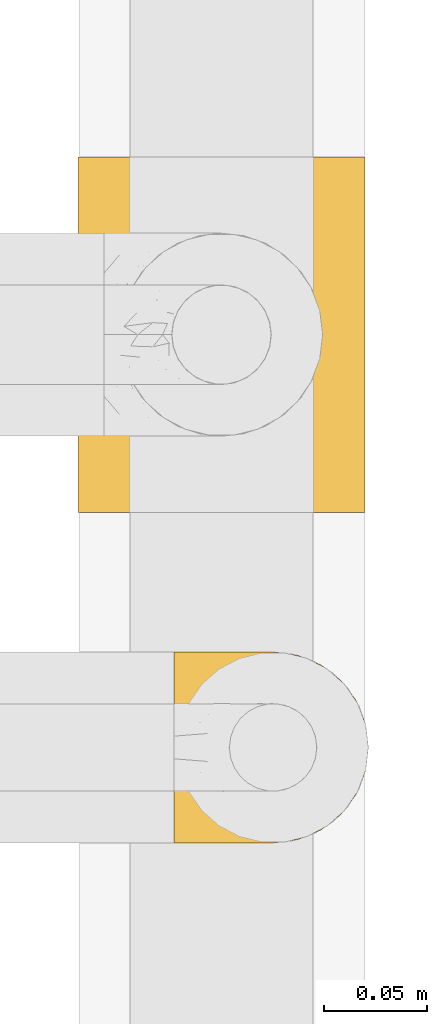
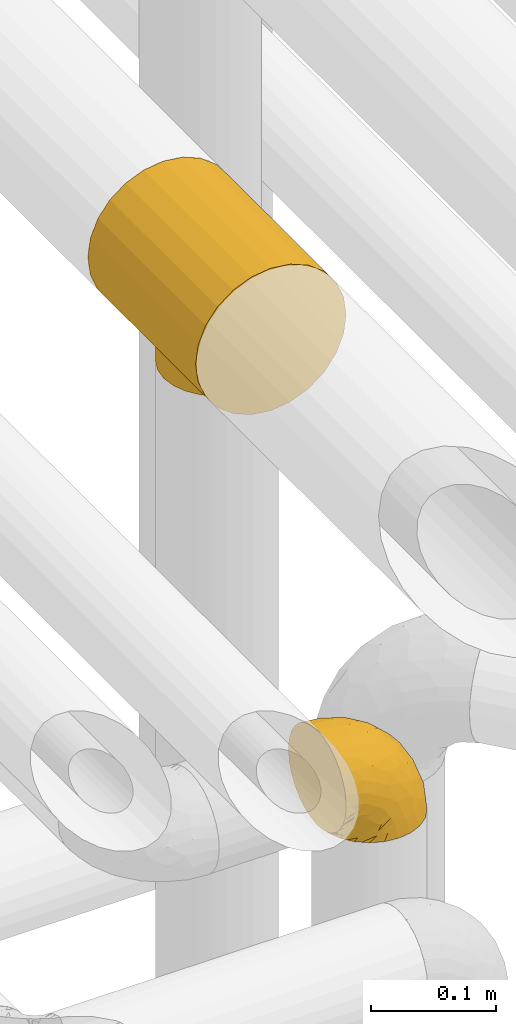
# One storey, part 209 of 827: 2 coverings.
"""IFC2X3 building model written with IfcOpenShell, lengths in millimetres."""

from ifc_helpers import new_model, entity, si_unit, converted_unit, derived_unit, direction, frame, origin, place, context, subcontext, project, spatial, faceted_brep, element, save


model = new_model("IFC2X3")

# Units and contexts
model_context = context("Model", 3, precision=0.01, world=origin(), true_north=direction((6.12303176911189e-17, 1.0)))
body_context = subcontext(model_context, "Body", "Model", "MODEL_VIEW")
ifc_project = project(units=[si_unit("LENGTHUNIT", "METRE", prefix="MILLI"), si_unit("AREAUNIT", "SQUARE_METRE"), si_unit("VOLUMEUNIT", "CUBIC_METRE"), converted_unit("PLANEANGLEUNIT", "DEGREE", entity("IfcRatioMeasure", 0.0174532925199433), si_unit("PLANEANGLEUNIT", "RADIAN"), dimensions=[0, 0, 0, 0, 0, 0, 0]), si_unit("MASSUNIT", "GRAM", prefix="KILO"), derived_unit("MASSDENSITYUNIT", [(si_unit("MASSUNIT", "GRAM", prefix="KILO"), 1), (si_unit("LENGTHUNIT", "METRE"), -3)]), derived_unit("MOMENTOFINERTIAUNIT", [(si_unit("LENGTHUNIT", "METRE"), 4)]), si_unit("TIMEUNIT", "SECOND"), si_unit("FREQUENCYUNIT", "HERTZ"), si_unit("THERMODYNAMICTEMPERATUREUNIT", "DEGREE_CELSIUS"), derived_unit("THERMALTRANSMITTANCEUNIT", [(si_unit("MASSUNIT", "GRAM", prefix="KILO"), 1), (si_unit("THERMODYNAMICTEMPERATUREUNIT", "KELVIN"), -1), (si_unit("TIMEUNIT", "SECOND"), -3)]), derived_unit("VOLUMETRICFLOWRATEUNIT", [(si_unit("LENGTHUNIT", "METRE"), 3), (si_unit("TIMEUNIT", "SECOND"), -1)]), derived_unit("MASSFLOWRATEUNIT", [(si_unit("MASSUNIT", "GRAM", prefix="KILO"), 1), (si_unit("TIMEUNIT", "SECOND"), -1)]), derived_unit("ROTATIONALFREQUENCYUNIT", [(si_unit("TIMEUNIT", "SECOND"), -1)]), si_unit("ELECTRICCURRENTUNIT", "AMPERE"), si_unit("ELECTRICVOLTAGEUNIT", "VOLT"), si_unit("POWERUNIT", "WATT"), si_unit("FORCEUNIT", "NEWTON", prefix="KILO"), si_unit("ILLUMINANCEUNIT", "LUX"), si_unit("LUMINOUSFLUXUNIT", "LUMEN"), si_unit("LUMINOUSINTENSITYUNIT", "CANDELA"), derived_unit("USERDEFINED", [(si_unit("MASSUNIT", "GRAM", prefix="KILO"), -1), (si_unit("LENGTHUNIT", "METRE"), -2), (si_unit("TIMEUNIT", "SECOND"), 3), (si_unit("LUMINOUSFLUXUNIT", "LUMEN"), 1)]), derived_unit("LINEARVELOCITYUNIT", [(si_unit("LENGTHUNIT", "METRE"), 1), (si_unit("TIMEUNIT", "SECOND"), -1)]), si_unit("PRESSUREUNIT", "PASCAL"), derived_unit("USERDEFINED", [(si_unit("LENGTHUNIT", "METRE"), -2), (si_unit("MASSUNIT", "GRAM", prefix="KILO"), 1), (si_unit("TIMEUNIT", "SECOND"), -2)]), derived_unit("LINEARFORCEUNIT", [(si_unit("MASSUNIT", "GRAM", prefix="KILO"), 1), (si_unit("LENGTHUNIT", "METRE"), 1), (si_unit("TIMEUNIT", "SECOND"), -2), (si_unit("LENGTHUNIT", "METRE"), -1)]), derived_unit("PLANARFORCEUNIT", [(si_unit("MASSUNIT", "GRAM", prefix="KILO"), 1), (si_unit("LENGTHUNIT", "METRE"), 1), (si_unit("TIMEUNIT", "SECOND"), -2), (si_unit("LENGTHUNIT", "METRE"), -2)])], contexts=[model_context])

# Site, building, storey
site_placement = place(None, origin())
site = spatial("IfcSite", under=ifc_project, at=site_placement, CompositionType="ELEMENT")
building_placement = place(site_placement, origin())
building = spatial("IfcBuilding", under=site, at=building_placement, CompositionType="ELEMENT")
storey_placement = place(building_placement, frame((0.0, 0.0, 28200.0)))
storey = spatial("IfcBuildingStorey", under=building, at=storey_placement, Name="08", CompositionType="ELEMENT", Elevation=28200.0)

# Coverings
covering_1_placement = place(storey_placement, frame((35893.45, 11758.41, 3150.4)))
element("IfcCovering", 1, at=covering_1_placement, inside=storey, Name=":ADSK_", ObjectType=":ADSK_", PredefinedType="INSULATION", context=body_context, shape_type="Brep", body=[
    faceted_brep([(1.6, 11.68, 78.41), (1.6, 19.0, 85.72), (1.6, 27.76, 91.22), (1.6, 37.52, 94.64), (1.6, 47.8, 95.8), (1.6, 58.08, 94.64), (1.6, 67.85, 91.22), (1.6, 76.61, 85.71), (1.6, 83.92, 78.39), (1.6, 89.42, 69.63), (1.6, 92.84, 59.87), (1.6, 94.0, 49.6), (1.6, 93.53, 45.45), (1.6, 93.18, 42.38), (1.6, 92.84, 39.31), (1.6, 91.13, 34.43), (1.6, 89.42, 29.54), (1.6, 86.66, 25.16), (1.6, 83.91, 20.78), (1.6, 80.25, 17.13), (1.6, 76.59, 13.47), (1.6, 67.83, 7.97), (1.6, 62.95, 6.26), (1.6, 58.07, 4.55), (1.6, 47.8, 3.4), (1.6, 37.51, 4.55), (1.6, 32.63, 6.26), (1.6, 27.74, 7.97), (1.6, 18.98, 13.48), (1.6, 15.33, 17.14), (1.6, 11.67, 20.8), (1.6, 8.92, 25.18), (1.6, 6.17, 29.56), (1.6, 4.46, 34.44), (1.6, 2.75, 39.32), (1.6, 2.41, 42.39), (1.6, 2.06, 45.45), (1.6, 1.6, 49.6), (1.6, 2.75, 59.88), (1.6, 6.17, 69.65), (3.4, 47.8, 1.6), (4.97, 59.75, 1.6), (9.58, 70.9, 1.6), (13.26, 75.68, 1.6), (16.93, 80.46, 1.6), (21.71, 84.13, 1.6), (26.5, 87.81, 1.6), (32.07, 90.11, 1.6), (37.64, 92.42, 1.6), (41.25, 92.9, 1.6), (43.34, 93.17, 1.6), (45.42, 93.45, 1.6), (49.6, 94.0, 1.6), (61.55, 92.42, 1.6), (72.7, 87.81, 1.6), (82.26, 80.46, 1.6), (89.61, 70.9, 1.6), (94.22, 59.75, 1.6), (95.8, 47.8, 1.6), (94.22, 35.84, 1.6), (89.61, 24.7, 1.6), (82.26, 15.13, 1.6), (72.7, 7.78, 1.6), (61.55, 3.17, 1.6), (49.6, 1.6, 1.6), (45.42, 2.14, 1.6), (41.25, 2.69, 1.6), (37.64, 3.17, 1.6), (32.07, 5.48, 1.6), (26.5, 7.78, 1.6), (21.71, 11.46, 1.6), (16.93, 15.13, 1.6), (13.26, 19.91, 1.6), (9.58, 24.7, 1.6), (4.97, 35.84, 1.6), (81.55, 23.61, 36.81), (90.4, 31.99, 23.28), (83.0, 35.87, 45.8), (91.18, 47.8, 30.7), (93.13, 40.43, 21.2), (94.0, 47.8, 12.96), (66.19, 31.83, 66.19), (70.92, 23.37, 54.51), (85.95, 21.41, 17.98), (49.74, 3.07, 36.69), (35.54, 1.6, 35.54), (38.14, 1.6, 31.64), (40.74, 1.6, 27.75), (43.34, 1.6, 23.86), (45.94, 1.6, 19.96), (77.59, 13.45, 22.8), (71.17, 15.25, 42.67), (65.81, 8.07, 33.21), (59.03, 16.0, 59.45), (45.85, 17.34, 71.5), (45.79, 10.58, 62.66), (41.42, 5.34, 54.5), (34.51, 2.39, 47.57), (56.04, 8.36, 48.81), (15.15, 10.04, 74.98), (56.51, 2.59, 18.7), (68.39, 6.28, 15.75), (23.33, 34.28, 91.17), (42.86, 38.73, 85.28), (39.42, 27.25, 82.58), (53.58, 29.88, 75.78), (59.17, 38.6, 74.98), (59.06, 23.44, 67.27), (22.63, 25.25, 87.38), (20.55, 17.23, 82.04), (12.96, 47.8, 94.0), (56.96, 47.8, 77.8), (67.38, 47.8, 67.38), (18.72, 2.53, 56.2), (5.33, 1.6, 48.85), (9.07, 1.6, 48.11), (11.79, 1.6, 47.57), (14.51, 1.6, 47.03), (17.24, 1.6, 46.48), (19.96, 1.6, 45.94), (21.03, 5.71, 65.78), (46.48, 1.6, 17.24), (47.03, 1.6, 14.51), (47.57, 1.6, 11.79), (48.11, 1.6, 9.07), (48.48, 1.6, 7.2), (48.85, 1.6, 5.33), (30.7, 47.8, 91.18), (23.86, 1.6, 43.34), (27.75, 1.6, 40.74), (31.64, 1.6, 38.14), (31.26, 11.89, 72.73), (77.8, 47.8, 56.96), (72.75, 39.69, 62.23), (43.83, 47.8, 84.49), (84.49, 47.8, 43.83), (14.58, 13.84, 12.05), (16.17, 9.16, 18.95), (10.82, 15.79, 13.02), (4.64, 25.75, 8.34), (7.71, 16.09, 14.63), (25.13, 7.51, 11.09), (32.66, 3.99, 13.66), (34.94, 2.66, 20.08), (36.76, 3.16, 9.61), (40.48, 2.35, 9.48), (39.25, 2.23, 16.1), (3.69, 38.35, 3.42), (13.99, 6.18, 26.63), (21.85, 2.7, 33.72), (17.93, 2.93, 34.77), (15.11, 16.01, 6.75), (21.14, 9.08, 13.31), (12.7, 9.3, 21.11), (7.21, 11.68, 19.94), (10.45, 21.65, 6.04), (32.27, 4.65, 8.67), (25.68, 3.65, 26.11), (22.18, 3.61, 29.3), (18.79, 12.8, 6.32), (10.12, 2.43, 39.92), (9.47, 6.83, 27.05), (11.29, 3.7, 34.4), (2.87, 47.8, 2.87), (31.16, 3.37, 20.92), (6.31, 7.03, 27.43), (25.62, 7.87, 7.54), (21.18, 7.26, 18.45), (28.81, 3.41, 23.88), (7.45, 23.81, 7.77), (21.17, 88.32, 18.43), (16.17, 86.42, 18.93), (25.69, 91.93, 26.08), (48.11, 94.0, 9.07), (48.85, 94.0, 5.33), (47.03, 94.0, 14.51), (47.57, 94.0, 11.79), (3.69, 57.24, 3.42), (7.44, 71.76, 7.76), (14.51, 94.0, 47.03), (11.79, 94.0, 47.57), (5.33, 94.0, 48.85), (9.07, 94.0, 48.11), (7.71, 79.49, 14.62), (9.47, 88.75, 27.03), (34.94, 92.93, 20.08), (31.16, 92.22, 20.92), (40.74, 94.0, 27.75), (38.14, 94.0, 31.64), (18.79, 82.79, 6.33), (36.76, 92.43, 9.61), (40.48, 93.24, 9.48), (4.63, 69.82, 8.33), (21.14, 86.5, 13.3), (15.11, 79.57, 6.74), (14.58, 81.74, 12.04), (43.34, 94.0, 23.86), (45.94, 94.0, 19.96), (39.25, 93.36, 16.1), (7.21, 83.9, 19.93), (12.69, 86.28, 21.1), (10.14, 93.16, 39.92), (21.81, 92.88, 33.68), (22.19, 91.98, 29.28), (14.0, 89.41, 26.62), (6.66, 88.82, 27.87), (17.92, 92.66, 34.75), (10.45, 73.93, 6.04), (31.64, 94.0, 38.14), (10.64, 79.5, 12.79), (11.31, 91.89, 34.41), (19.96, 94.0, 45.94), (23.86, 94.0, 43.34), (27.75, 94.0, 40.74), (32.66, 91.6, 13.66), (46.48, 94.0, 17.24), (32.27, 90.94, 8.67), (25.13, 88.08, 11.09), (35.54, 94.0, 35.54), (28.77, 92.16, 23.83), (23.36, 86.13, 6.03), (17.24, 94.0, 46.48), (47.58, 93.2, 34.52), (93.13, 55.16, 21.2), (77.44, 82.02, 23.82), (66.78, 84.29, 41.32), (71.68, 76.94, 47.62), (74.96, 68.33, 52.66), (81.55, 71.98, 36.81), (36.7, 92.52, 49.75), (56.9, 92.9, 19.07), (83.0, 59.72, 45.8), (90.4, 63.6, 23.28), (67.83, 88.89, 21.35), (85.95, 74.18, 17.98), (39.41, 68.35, 82.57), (23.33, 61.33, 91.17), (42.87, 56.86, 85.27), (53.92, 68.62, 73.89), (66.19, 63.76, 66.19), (64.12, 72.19, 62.43), (33.13, 88.69, 63.53), (23.1, 92.19, 58.45), (16.98, 89.75, 67.16), (72.75, 55.9, 62.22), (23.77, 77.99, 81.54), (18.41, 85.21, 74.8), (43.7, 74.99, 75.83), (54.53, 90.23, 41.45), (55.72, 59.86, 76.72), (17.73, 70.75, 88.2), (38.98, 81.72, 71.6), (50.28, 86.53, 56.23), (59.02, 79.6, 59.44)], [[[0, 1, 2, 3, 4, 5, 6, 7, 8, 9, 10, 11, 12, 13, 14, 15, 16, 17, 18, 19, 20, 21, 22, 23, 24, 25, 26, 27, 28, 29, 30, 31, 32, 33, 34, 35, 36, 37, 38, 39]], [[40, 41, 42, 43, 44, 45, 46, 47, 48, 49, 50, 51, 52, 53, 54, 55, 56, 57, 58, 59, 60, 61, 62, 63, 64, 65, 66, 67, 68, 69, 70, 71, 72, 73, 74]], [[75, 76, 77]], [[78, 79, 80]], [[77, 81, 82]], [[76, 75, 83]], [[84, 85, 86, 87, 88, 89]], [[90, 91, 92]], [[76, 60, 59]], [[93, 94, 95]], [[90, 62, 61]], [[83, 61, 60]], [[96, 97, 84]], [[98, 93, 95]], [[0, 39, 99]], [[100, 84, 89]], [[62, 101, 63]], [[2, 102, 3]], [[92, 84, 100]], [[103, 102, 104]], [[103, 105, 106]], [[93, 107, 94]], [[1, 108, 2]], [[92, 101, 90]], [[108, 1, 109]], [[102, 110, 3]], [[93, 82, 107]], [[102, 108, 104]], [[111, 106, 112]], [[109, 0, 99]], [[113, 37, 114, 115, 116, 117, 118, 119]], [[120, 38, 113]], [[100, 89, 121, 122, 123, 124, 125, 126, 64]], [[127, 102, 103]], [[97, 119, 128, 129, 130, 85]], [[99, 120, 131]], [[132, 133, 77]], [[59, 80, 79]], [[1, 0, 109]], [[98, 84, 92]], [[94, 109, 131]], [[120, 39, 38]], [[93, 91, 82]], [[104, 94, 105]], [[97, 113, 119]], [[95, 120, 96]], [[83, 90, 61]], [[91, 93, 98]], [[64, 63, 100]], [[100, 63, 101]], [[77, 76, 79]], [[133, 106, 81]], [[84, 97, 85]], [[113, 96, 120]], [[113, 97, 96]], [[37, 113, 38]], [[110, 102, 127]], [[110, 4, 3]], [[103, 111, 134, 127]], [[90, 75, 91]], [[82, 81, 107]], [[91, 75, 82]], [[77, 82, 75]], [[76, 83, 60]], [[90, 83, 75]], [[105, 107, 81]], [[94, 131, 95]], [[105, 94, 107]], [[109, 94, 104]], [[120, 95, 131]], [[98, 95, 96]], [[84, 98, 96]], [[98, 92, 91]], [[106, 105, 81]], [[103, 104, 105]], [[112, 106, 133]], [[103, 106, 111]], [[112, 133, 132]], [[81, 77, 133]], [[77, 78, 135, 132]], [[120, 99, 39]], [[109, 99, 131]], [[59, 58, 80]], [[59, 79, 76]], [[90, 101, 62]], [[100, 101, 92]], [[2, 108, 102]], [[109, 104, 108]], [[78, 77, 79]], [[136, 137, 138]], [[27, 139, 140]], [[141, 142, 143]], [[144, 145, 121]], [[146, 89, 88]], [[147, 139, 25]], [[148, 149, 150]], [[136, 151, 152]], [[147, 40, 74]], [[24, 147, 25]], [[140, 153, 154]], [[33, 116, 34]], [[73, 151, 155]], [[114, 37, 36, 35, 34, 116, 115]], [[146, 156, 144]], [[157, 85, 130]], [[158, 149, 148]], [[151, 159, 152]], [[117, 33, 160]], [[29, 154, 161]], [[155, 74, 73]], [[162, 128, 119]], [[66, 65, 64, 126, 125, 124, 123, 122, 67]], [[163, 147, 24]], [[27, 140, 28]], [[149, 129, 150]], [[139, 27, 26, 25]], [[68, 144, 69]], [[129, 128, 150]], [[164, 87, 86]], [[130, 129, 149]], [[122, 145, 67]], [[154, 153, 148]], [[162, 119, 160]], [[165, 30, 161]], [[150, 161, 148]], [[128, 162, 150]], [[30, 165, 31]], [[145, 144, 68]], [[89, 146, 144]], [[87, 164, 143]], [[166, 156, 142]], [[88, 87, 143]], [[162, 161, 150]], [[161, 30, 29]], [[154, 29, 28]], [[140, 154, 28]], [[161, 154, 148]], [[140, 137, 153]], [[158, 148, 153]], [[157, 130, 158]], [[153, 137, 158]], [[158, 137, 157]], [[167, 137, 136]], [[168, 85, 157]], [[152, 168, 167]], [[167, 168, 157]], [[164, 152, 141]], [[151, 73, 72]], [[159, 72, 71]], [[88, 142, 146]], [[144, 156, 69]], [[146, 142, 156]], [[70, 166, 71]], [[142, 141, 166]], [[70, 69, 156]], [[141, 159, 71]], [[167, 136, 152]], [[138, 137, 140]], [[155, 136, 169]], [[136, 155, 151]], [[74, 155, 169]], [[152, 159, 141]], [[151, 72, 159]], [[168, 152, 164]], [[137, 167, 157]], [[164, 86, 168]], [[85, 168, 86]], [[116, 33, 117]], [[130, 149, 158]], [[67, 145, 68]], [[121, 89, 144]], [[145, 122, 121]], [[40, 147, 163]], [[169, 147, 74]], [[160, 33, 32]], [[162, 160, 32]], [[160, 119, 118, 117]], [[139, 147, 169]], [[139, 169, 138]], [[162, 32, 31]], [[141, 143, 164]], [[88, 143, 142]], [[71, 166, 141]], [[156, 166, 70]], [[139, 138, 140]], [[169, 136, 138]], [[161, 162, 165]], [[162, 31, 165]], [[170, 171, 172]], [[173, 174, 52, 51, 50, 49, 48, 175, 176]], [[177, 178, 41]], [[179, 15, 180]], [[12, 11, 181, 182, 180, 14, 13]], [[183, 21, 20]], [[19, 18, 184]], [[185, 186, 187]], [[186, 188, 187]], [[43, 189, 44]], [[190, 191, 47]], [[23, 22, 21, 192]], [[193, 194, 195]], [[40, 163, 177]], [[196, 197, 198]], [[24, 23, 177]], [[199, 200, 183]], [[201, 15, 179]], [[47, 46, 190]], [[202, 203, 204]], [[203, 172, 171]], [[205, 206, 184]], [[207, 41, 178]], [[16, 15, 201]], [[14, 180, 15]], [[204, 203, 200]], [[208, 203, 202]], [[163, 24, 177]], [[48, 47, 191]], [[198, 197, 190]], [[199, 184, 204]], [[171, 195, 209]], [[210, 211, 212]], [[206, 212, 213]], [[205, 17, 210]], [[184, 206, 204]], [[210, 212, 206]], [[185, 196, 214]], [[190, 215, 191]], [[216, 45, 214]], [[186, 217, 193]], [[190, 216, 198]], [[199, 20, 19]], [[196, 185, 187]], [[199, 183, 20]], [[184, 199, 19]], [[199, 204, 200]], [[206, 202, 204]], [[171, 183, 200]], [[203, 208, 172]], [[172, 208, 218]], [[171, 200, 203]], [[218, 188, 219]], [[195, 170, 193]], [[217, 186, 185]], [[193, 219, 186]], [[193, 170, 219]], [[207, 194, 42]], [[217, 220, 189]], [[216, 190, 46]], [[214, 196, 198]], [[44, 220, 45]], [[214, 198, 216]], [[216, 46, 45]], [[214, 45, 220]], [[42, 194, 43]], [[189, 193, 217]], [[207, 195, 194]], [[209, 195, 178]], [[41, 207, 42]], [[195, 207, 178]], [[43, 194, 189]], [[193, 189, 194]], [[171, 170, 195]], [[170, 172, 219]], [[218, 219, 172]], [[188, 186, 219]], [[206, 213, 202]], [[208, 202, 213]], [[201, 210, 16]], [[215, 190, 197]], [[215, 175, 191]], [[175, 48, 191]], [[201, 179, 221, 211]], [[210, 201, 211]], [[23, 192, 177]], [[40, 177, 41]], [[183, 209, 192]], [[183, 192, 21]], [[192, 178, 177]], [[205, 18, 17]], [[17, 16, 210]], [[217, 185, 214]], [[189, 220, 44]], [[214, 220, 217]], [[192, 209, 178]], [[171, 209, 183]], [[206, 205, 210]], [[18, 205, 184]], [[222, 197, 196, 187, 188, 218]], [[57, 223, 80]], [[224, 225, 226]], [[226, 227, 228]], [[229, 218, 208, 213, 212, 211]], [[230, 52, 174, 173, 176, 175, 215, 197]], [[231, 232, 228]], [[231, 78, 223]], [[223, 57, 232]], [[224, 233, 225]], [[233, 54, 53]], [[234, 232, 56]], [[56, 55, 234]], [[234, 224, 228]], [[235, 236, 237]], [[224, 55, 54]], [[238, 239, 240]], [[52, 230, 53]], [[241, 242, 243]], [[231, 227, 244]], [[11, 10, 242]], [[236, 6, 5]], [[7, 245, 8]], [[8, 246, 9]], [[238, 247, 235]], [[222, 229, 248]], [[242, 211, 221, 179, 180, 182, 181, 11]], [[233, 53, 230]], [[111, 112, 249]], [[250, 6, 236]], [[246, 251, 241]], [[6, 250, 7]], [[127, 236, 110]], [[248, 229, 252]], [[246, 8, 245]], [[235, 245, 250]], [[236, 5, 110]], [[235, 249, 238]], [[237, 236, 127]], [[243, 9, 246]], [[252, 229, 241]], [[56, 232, 57]], [[222, 230, 197]], [[225, 248, 252]], [[248, 233, 230]], [[54, 233, 224]], [[231, 228, 227]], [[244, 132, 231]], [[248, 225, 233]], [[226, 225, 253]], [[235, 250, 236]], [[245, 7, 250]], [[251, 246, 245]], [[243, 246, 241]], [[247, 245, 235]], [[252, 251, 253]], [[229, 222, 218]], [[230, 222, 248]], [[5, 4, 110]], [[237, 127, 134, 111]], [[238, 249, 239]], [[224, 234, 55]], [[232, 234, 228]], [[242, 241, 229]], [[10, 9, 243]], [[211, 242, 229]], [[10, 243, 242]], [[80, 223, 78]], [[80, 58, 57]], [[231, 223, 232]], [[227, 240, 239]], [[224, 226, 228]], [[240, 226, 253]], [[227, 239, 244]], [[226, 240, 227]], [[251, 247, 253]], [[240, 253, 247]], [[249, 235, 237]], [[237, 111, 249]], [[244, 239, 249]], [[112, 244, 249]], [[135, 78, 231, 132]], [[112, 132, 244]], [[247, 238, 240]], [[245, 247, 251]], [[251, 252, 241]], [[225, 252, 253]]]),
])
covering_2_placement = place(storey_placement, frame((35847.02, 11920.08, 3477.0)))
element("IfcCovering", 2, at=covering_2_placement, inside=storey, Name=":ADSK_", ObjectType=":ADSK_", PredefinedType="INSULATION", context=body_context, shape_type="Brep", body=[
    faceted_brep([(3.96, 172.0, 90.97), (10.9, 172.0, 107.72), (21.94, 172.0, 122.11), (36.32, 172.0, 133.15), (53.07, 172.0, 140.08), (71.05, 172.0, 142.45), (89.02, 172.0, 140.08), (105.77, 172.0, 133.15), (120.15, 172.0, 122.11), (131.19, 172.0, 107.72), (138.13, 172.0, 90.97), (140.5, 172.0, 73.0), (138.13, 172.0, 55.03), (131.19, 172.0, 38.27), (120.15, 172.0, 23.89), (105.77, 172.0, 12.85), (97.4, 172.0, 9.39), (89.02, 172.0, 5.92), (80.03, 172.0, 4.73), (71.05, 172.0, 3.55), (62.06, 172.0, 4.73), (53.07, 172.0, 5.92), (44.7, 172.0, 9.39), (36.32, 172.0, 12.85), (21.94, 172.0, 23.89), (10.9, 172.0, 38.27), (3.96, 172.0, 55.03), (1.6, 172.0, 73.0), (120.15, 0.0, 122.11), (105.77, 0.0, 133.15), (89.02, 0.0, 140.08), (71.05, 0.0, 142.45), (53.07, 0.0, 140.08), (36.32, 0.0, 133.15), (21.94, 0.0, 122.11), (10.9, 0.0, 107.73), (3.96, 0.0, 90.97), (1.6, 0.0, 73.0), (3.96, 0.0, 55.03), (10.9, 0.0, 38.28), (21.94, 0.0, 23.89), (36.32, 0.0, 12.85), (44.7, 0.0, 9.39), (53.07, 0.0, 5.92), (62.06, 0.0, 4.73), (71.05, 0.0, 3.55), (80.03, 0.0, 4.73), (89.02, 0.0, 5.92), (97.4, 0.0, 9.39), (105.77, 0.0, 12.85), (120.15, 0.0, 23.89), (131.19, 0.0, 38.28), (138.13, 0.0, 55.03), (140.5, 0.0, 73.0), (138.13, 0.0, 90.97), (131.19, 0.0, 107.73), (109.48, 55.36, 15.15), (115.18, 64.37, 19.38), (92.88, 130.03, 7.07), (118.88, 74.72, 22.65), (82.39, 38.18, 4.48), (120.2, 86.0, 23.93), (118.88, 97.28, 22.65), (82.39, 133.82, 4.48), (76.72, 134.49, 4.02), (71.05, 135.15, 3.55), (109.48, 116.64, 15.15), (115.18, 107.63, 19.38), (102.0, 47.82, 10.83), (92.88, 41.97, 7.07), (71.05, 36.85, 3.55), (76.72, 37.51, 4.02), (87.64, 40.07, 5.78), (102.0, 124.18, 10.83), (87.64, 131.93, 5.78), (59.7, 38.18, 4.48), (40.09, 47.82, 10.83), (49.21, 41.97, 7.07), (54.46, 40.07, 5.78), (65.38, 134.49, 4.02), (59.7, 133.82, 4.48), (40.09, 124.18, 10.83), (49.21, 130.03, 7.07), (32.61, 116.64, 15.15), (54.46, 131.93, 5.78), (32.61, 55.36, 15.15), (26.91, 64.37, 19.38), (23.21, 74.72, 22.65), (65.38, 37.51, 4.02), (21.9, 86.0, 23.93), (26.91, 107.63, 19.38), (23.21, 97.28, 22.65), (118.52, 73.28, 0.0), (113.61, 61.42, 0.0), (105.8, 51.25, 0.0), (95.62, 43.43, 0.0), (89.69, 40.98, 0.0), (83.77, 38.52, 0.0), (77.41, 37.69, 0.0), (71.05, 36.85, 0.0), (64.68, 37.69, 0.0), (58.32, 38.52, 0.0), (52.4, 40.98, 0.0), (46.47, 43.43, 0.0), (36.29, 51.25, 0.0), (28.48, 61.42, 0.0), (23.57, 73.28, 0.0), (21.9, 86.0, 0.0), (23.57, 98.72, 0.0), (28.48, 110.57, 0.0), (36.29, 120.75, 0.0), (46.47, 128.57, 0.0), (52.4, 131.02, 0.0), (58.32, 133.48, 0.0), (64.68, 134.31, 0.0), (71.05, 135.15, 0.0), (77.41, 134.31, 0.0), (83.77, 133.48, 0.0), (89.69, 131.02, 0.0), (95.62, 128.57, 0.0), (105.8, 120.75, 0.0), (113.61, 110.57, 0.0), (118.52, 98.72, 0.0), (120.2, 86.0, 0.0)], [[[0, 1, 2, 3, 4, 5, 6, 7, 8, 9, 10, 11, 12, 13, 14, 15, 16, 17, 18, 19, 20, 21, 22, 23, 24, 25, 26, 27]], [[28, 29, 30, 31, 32, 33, 34, 35, 36, 37, 38, 39, 40, 41, 42, 43, 44, 45, 46, 47, 48, 49, 50, 51, 52, 53, 54, 55]], [[29, 28, 8, 7]], [[5, 31, 30, 6]], [[7, 6, 30, 29]], [[9, 55, 54, 10]], [[10, 54, 53, 11]], [[8, 28, 55, 9]], [[52, 12, 11, 53]], [[51, 13, 12, 52]], [[50, 56, 57]], [[56, 50, 49]], [[58, 17, 16]], [[57, 59, 50]], [[60, 47, 46]], [[51, 50, 61]], [[50, 59, 61]], [[61, 62, 14]], [[18, 63, 64, 65]], [[66, 14, 67]], [[67, 14, 62]], [[68, 48, 69]], [[61, 14, 13]], [[61, 13, 51]], [[48, 68, 49]], [[69, 48, 47]], [[45, 70, 46]], [[65, 19, 18]], [[46, 70, 71, 60]], [[47, 60, 72, 69]], [[66, 73, 15]], [[73, 16, 15]], [[16, 73, 58]], [[66, 15, 14]], [[18, 17, 63]], [[17, 58, 74, 63]], [[68, 56, 49]], [[45, 44, 70]], [[65, 20, 19]], [[75, 44, 43]], [[41, 76, 42]], [[77, 42, 76]], [[43, 77, 78, 75]], [[20, 65, 79, 80]], [[81, 23, 22]], [[22, 21, 82]], [[23, 81, 83]], [[21, 80, 84, 82]], [[85, 76, 41]], [[86, 85, 40]], [[87, 86, 40]], [[44, 75, 88, 70]], [[39, 38, 26, 25]], [[89, 40, 39]], [[87, 40, 89]], [[85, 41, 40]], [[26, 38, 37, 27]], [[90, 91, 24]], [[80, 21, 20]], [[83, 24, 23]], [[24, 83, 90]], [[91, 89, 24]], [[77, 43, 42]], [[89, 25, 24]], [[89, 39, 25]], [[81, 22, 82]], [[0, 36, 35, 1]], [[1, 35, 34, 2]], [[37, 36, 0, 27]], [[3, 33, 32, 4]], [[4, 32, 31, 5]], [[2, 34, 33, 3]], [[92, 93, 94, 95, 96, 97, 98, 99, 100, 101, 102, 103, 104, 105, 106, 107, 108, 109, 110, 111, 112, 113, 114, 115, 116, 117, 118, 119, 120, 121, 122, 123]], [[60, 98, 97]], [[69, 96, 95]], [[99, 71, 70]], [[99, 98, 71]], [[97, 72, 60]], [[68, 69, 95]], [[96, 72, 97]], [[98, 60, 71]], [[95, 94, 68]], [[56, 94, 93]], [[92, 123, 59]], [[57, 93, 92]], [[96, 69, 72]], [[56, 93, 57]], [[59, 57, 92]], [[61, 59, 123]], [[94, 56, 68]], [[62, 123, 122]], [[67, 122, 121]], [[61, 123, 62]], [[115, 64, 116]], [[62, 122, 67]], [[121, 66, 67]], [[121, 120, 66]], [[73, 120, 119]], [[63, 74, 117]], [[64, 115, 65]], [[63, 117, 116]], [[58, 73, 119]], [[58, 119, 118]], [[63, 116, 64]], [[118, 74, 58]], [[117, 74, 118]], [[120, 73, 66]], [[80, 114, 113]], [[82, 112, 111]], [[115, 79, 65]], [[115, 114, 79]], [[113, 84, 80]], [[81, 82, 111]], [[112, 84, 113]], [[114, 80, 79]], [[111, 110, 81]], [[83, 110, 109]], [[109, 108, 90]], [[107, 91, 108]], [[112, 82, 84]], [[83, 109, 90]], [[91, 90, 108]], [[89, 91, 107]], [[110, 83, 81]], [[87, 107, 106]], [[86, 106, 105]], [[89, 107, 87]], [[99, 88, 100]], [[87, 106, 86]], [[105, 85, 86]], [[105, 104, 85]], [[76, 104, 103]], [[75, 78, 101]], [[88, 99, 70]], [[75, 101, 100]], [[77, 76, 103]], [[77, 103, 102]], [[75, 100, 88]], [[102, 78, 77]], [[101, 78, 102]], [[104, 76, 85]]]),
])

save(model, "model.ifc")
